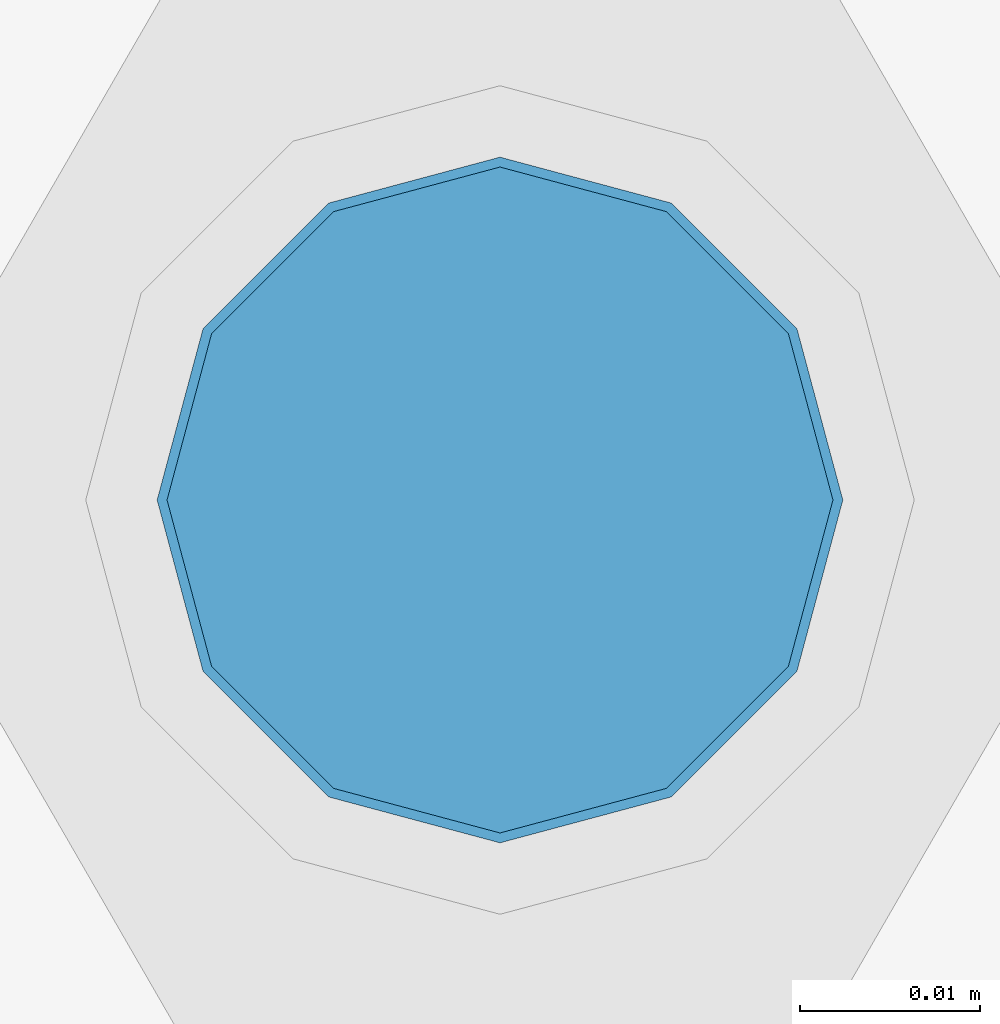
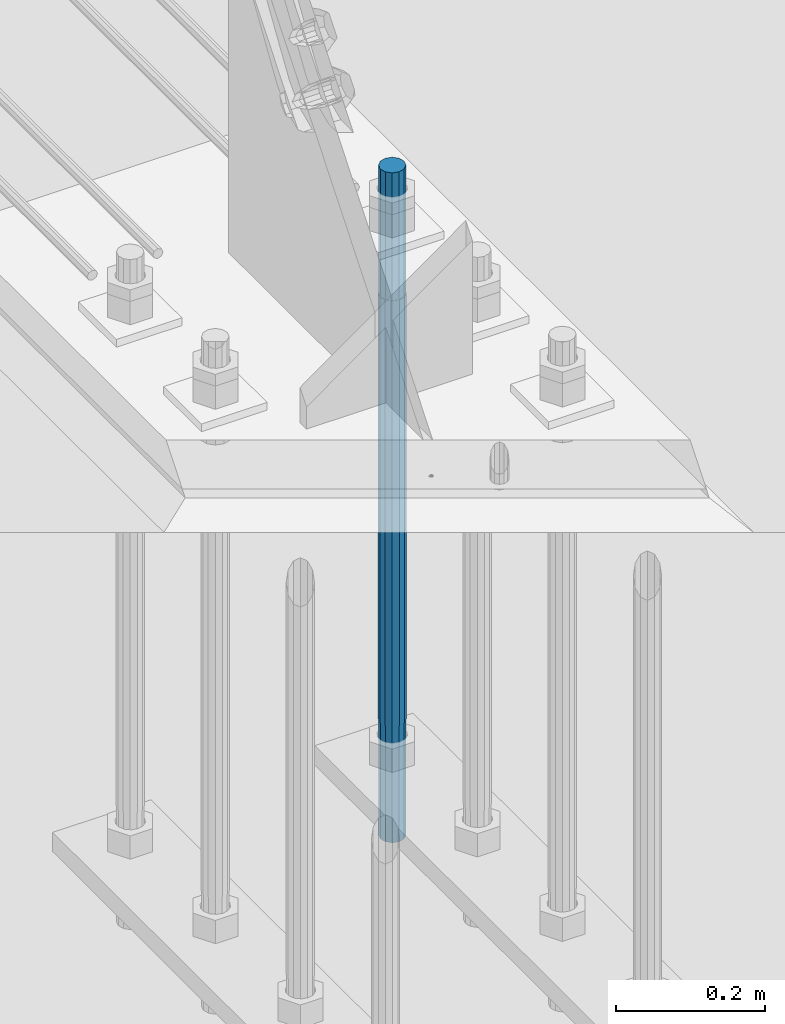
# One storey, part 1347 of 3843: 1 column, 1 element without a shape of its own.
"""IFC2X3 building model written with IfcOpenShell, lengths in millimetres."""

from ifc_helpers import new_model, si_unit, frame, origin_with_axes, place, context, subcontext, project, spatial, faceted_brep, material, type_object, element, aggregate, save


model = new_model("IFC2X3")

# Units and contexts
model_context = context("Model", 3, precision=1e-05, world=origin_with_axes())
body_context = subcontext(model_context, "Body", "Model", "MODEL_VIEW")
ifc_project = project(units=[si_unit("LENGTHUNIT", "METRE", prefix="MILLI"), si_unit("AREAUNIT", "SQUARE_METRE"), si_unit("VOLUMEUNIT", "CUBIC_METRE"), si_unit("MASSUNIT", "GRAM", prefix="KILO"), si_unit("TIMEUNIT", "SECOND"), si_unit("PLANEANGLEUNIT", "RADIAN"), si_unit("SOLIDANGLEUNIT", "STERADIAN"), si_unit("THERMODYNAMICTEMPERATUREUNIT", "DEGREE_CELSIUS"), si_unit("LUMINOUSINTENSITYUNIT", "LUMEN")], contexts=[model_context])

# Site, building, storey
site_placement = place(None, origin_with_axes())
site = spatial("IfcSite", under=ifc_project, at=site_placement, CompositionType="ELEMENT")
building_placement = place(site_placement, origin_with_axes())
building = spatial("IfcBuilding", under=site, at=building_placement, Name="Undefined", CompositionType="ELEMENT")
storey_placement = place(building_placement, origin_with_axes())
storey = spatial("IfcBuildingStorey", under=building, at=storey_placement, Name="Undefined", CompositionType="ELEMENT", Elevation=0.0)

# Assembly, column
assembly_placement = place(storey_placement, origin_with_axes())
assembly = element("IfcElementAssembly", 1, at=assembly_placement, inside=storey, Name="TEMPLATE", AssemblyPlace="NOTDEFINED", PredefinedType="RIGID_FRAME")
ifc_material = material(Name="Undefined/F1554-GR.55")
column_type = type_object("IfcColumnType", PredefinedType="NOTDEFINED")
column_placement = place(assembly_placement, frame((203.2, 96939.1, 29718.0), z_axis=(0.0, 1.0, 0.0), x_axis=(0.0, 0.0, -1.0)))
column = element("IfcColumn", 2, at=column_placement, type_object=column_type, material=ifc_material, Name="ANCHOR_ROD", context=body_context, shape_type="Brep", body=[
    faceted_brep([(-209.549999999999, -16.0214699700155, 9.25), (-209.549999999999, -9.25, 16.0214699700118), (-209.549999999999, 0.0, 18.5), (-209.549999999999, 9.25, 16.0214699700118), (-209.549999999999, 16.0214699700155, 9.25), (-209.549999999999, 18.5, 0.0), (-209.549999999999, 16.0214699700155, -9.25), (-209.549999999999, 9.25, -16.0214699700118), (-209.549999999999, 0.0, -18.5), (-209.549999999999, -9.25, -16.0214699700118), (-209.549999999999, -16.0214699700155, -9.25), (-209.549999999999, -18.5, 0.0), (0.0, 18.5, 0.0), (0.0, 16.0214699700118, -9.25), (0.0, 9.25, -16.0214699700155), (0.0, 0.0, -18.5), (0.0, -9.25, -16.0214699700155), (0.0, -16.0214699700118, -9.25), (0.0, -18.5, 0.0), (0.0, -16.0214699700118, 9.25), (0.0, -9.25, 16.0214699700155), (0.0, 0.0, 18.5), (0.0, 9.25, 16.0214699700155), (0.0, 16.0214699700118, 9.25), (0.0, -16.4977839420972, 9.52500000000146), (0.0, -9.52500000000146, 16.4977839420972), (0.0, 0.0, 19.0499989999989), (0.0, 9.52500000000146, 16.4977839420972), (0.0, 16.4977839420972, 9.52500000000146), (0.0, 19.0500000000029, 0.0), (0.0, 16.4977839420972, -9.52500000000146), (0.0, 9.52500000000146, -16.4977839420972), (0.0, 0.0, -19.0499989999989), (0.0, -9.52500000000146, -16.4977839420972), (0.0, -16.4977839420972, -9.52500000000146), (0.0, -19.0500000000029, 0.0), (698.5, -19.0499999999993, 0.0), (698.5, -16.4977839420935, 9.52499999999418), (698.5, -9.52500000000146, 16.4977839420899), (698.5, 0.0, 19.0500000000029), (698.5, 9.52500000000146, 16.4977839420899), (698.5, 16.4977839420935, 9.52499999999418), (698.5, 19.0499999999993, 0.0), (698.5, 16.4977839420935, -9.52499999999418), (698.5, 9.52500000000146, -16.4977839420899), (698.5, 0.0, -19.0500000000029), (698.5, -9.52500000000146, -16.4977839420899), (698.5, -16.4977839420935, -9.52499999999418), (698.5, -9.25, 16.0214699700155), (698.5, 0.0, 18.5), (698.5, 9.25, 16.0214699700155), (698.5, 16.0214699700118, 9.25), (698.5, 18.5, 0.0), (698.5, 16.0214699700118, -9.25), (698.5, 9.25, -16.0214699700155), (698.5, 0.0, -18.5), (698.5, -9.25, -16.0214699700155), (698.5, -16.0214699700118, -9.25), (698.5, -18.5, 0.0), (698.5, -16.0214699700118, 9.25), (889.0, -9.25, -16.0214699700155), (889.0, 0.0, -18.5), (889.0, 9.25, -16.0214699700155), (889.0, 16.0214699700118, -9.25), (889.0, 18.5, 0.0), (889.0, 16.0214699700118, 9.25), (889.0, 9.25, 16.0214699700155), (889.0, 0.0, 18.5), (889.0, -9.25, 16.0214699700155), (889.0, -16.0214699700118, 9.25), (889.0, -18.5, 0.0), (889.0, -16.0214699700118, -9.25)], [[[0, 1, 2, 3, 4, 5, 6, 7, 8, 9, 10, 11]], [[6, 5, 12, 13]], [[7, 6, 13, 14]], [[8, 7, 14, 15]], [[9, 8, 15, 16]], [[10, 9, 16, 17]], [[11, 10, 17, 18]], [[0, 11, 18, 19]], [[1, 0, 19, 20]], [[2, 1, 20, 21]], [[3, 2, 21, 22]], [[4, 3, 22, 23]], [[5, 4, 23, 12]], [[24, 25, 26, 27, 28, 29, 30, 31, 32, 33, 34, 35], [22, 21, 20, 19, 18, 17, 16, 15, 14, 13, 12, 23]], [[24, 35, 36, 37]], [[25, 24, 37, 38]], [[26, 25, 38, 39]], [[27, 26, 39, 40]], [[28, 27, 40, 41]], [[29, 28, 41, 42]], [[30, 29, 42, 43]], [[31, 30, 43, 44]], [[32, 31, 44, 45]], [[33, 32, 45, 46]], [[34, 33, 46, 47]], [[35, 34, 47, 36]], [[46, 45, 44, 43, 42, 41, 40, 39, 38, 37, 36, 47], [48, 49, 50, 51, 52, 53, 54, 55, 56, 57, 58, 59]], [[60, 61, 62, 63, 64, 65, 66, 67, 68, 69, 70, 71]], [[68, 67, 49, 48]], [[69, 68, 48, 59]], [[70, 69, 59, 58]], [[71, 70, 58, 57]], [[60, 71, 57, 56]], [[61, 60, 56, 55]], [[62, 61, 55, 54]], [[63, 62, 54, 53]], [[64, 63, 53, 52]], [[65, 64, 52, 51]], [[66, 65, 51, 50]], [[67, 66, 50, 49]]]),
])
aggregate(assembly, [column])

save(model, "model.ifc")
